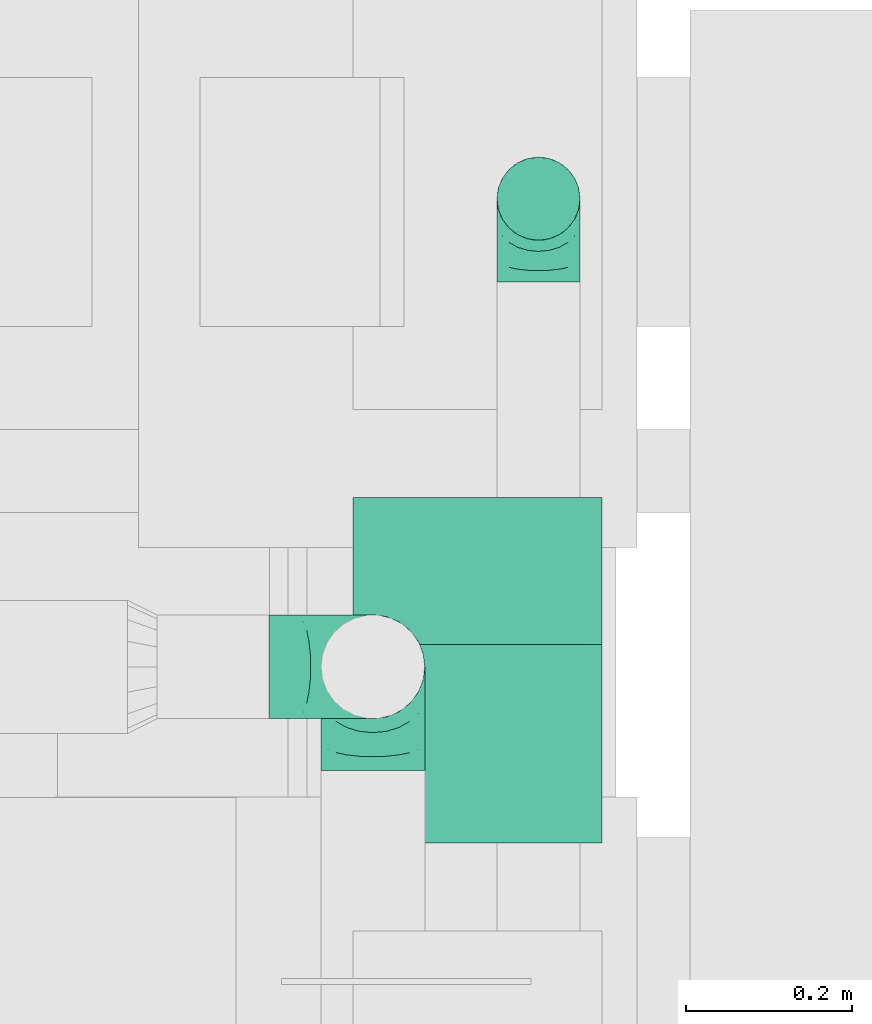
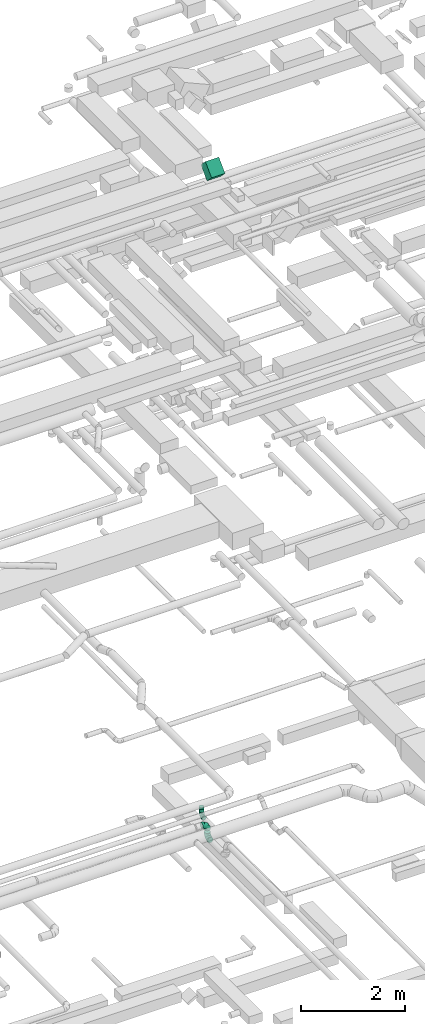
# One storey, part 110 of 337: 4 flow fittings, 2 flow segments.
"""IFC2X3 building model written with IfcOpenShell, lengths in millimetres."""

from ifc_helpers import new_model, entity, si_unit, converted_unit, derived_unit, direction, frame, frame_2d, origin, origin_2d_with_axis, place, context, subcontext, project, spatial, rectangle, circle, extrude, faceted_brep, source, transform, mapped, material, type_object, type_shapes, element, save


model = new_model("IFC2X3")

# Units and contexts
model_context = context("Model", 3, precision=0.01, world=origin(), true_north=direction((6.12303176911189e-17, 1.0)))
body_context = subcontext(model_context, "Body", "Model", "MODEL_VIEW")
ifc_project = project(units=[si_unit("LENGTHUNIT", "METRE", prefix="MILLI"), si_unit("AREAUNIT", "SQUARE_METRE"), si_unit("VOLUMEUNIT", "CUBIC_METRE"), converted_unit("PLANEANGLEUNIT", "DEGREE", entity("IfcRatioMeasure", 0.0174532925199433), si_unit("PLANEANGLEUNIT", "RADIAN"), dimensions=[0, 0, 0, 0, 0, 0, 0]), si_unit("MASSUNIT", "GRAM", prefix="KILO"), derived_unit("MASSDENSITYUNIT", [(si_unit("MASSUNIT", "GRAM", prefix="KILO"), 1), (si_unit("LENGTHUNIT", "METRE"), -3)]), derived_unit("MOMENTOFINERTIAUNIT", [(si_unit("LENGTHUNIT", "METRE"), 4)]), si_unit("TIMEUNIT", "SECOND"), si_unit("FREQUENCYUNIT", "HERTZ"), si_unit("THERMODYNAMICTEMPERATUREUNIT", "DEGREE_CELSIUS"), derived_unit("THERMALTRANSMITTANCEUNIT", [(si_unit("MASSUNIT", "GRAM", prefix="KILO"), 1), (si_unit("THERMODYNAMICTEMPERATUREUNIT", "KELVIN"), -1), (si_unit("TIMEUNIT", "SECOND"), -3)]), derived_unit("VOLUMETRICFLOWRATEUNIT", [(si_unit("LENGTHUNIT", "METRE"), 3), (si_unit("TIMEUNIT", "SECOND"), -1)]), derived_unit("MASSFLOWRATEUNIT", [(si_unit("MASSUNIT", "GRAM", prefix="KILO"), 1), (si_unit("TIMEUNIT", "SECOND"), -1)]), derived_unit("ROTATIONALFREQUENCYUNIT", [(si_unit("TIMEUNIT", "SECOND"), -1)]), si_unit("ELECTRICCURRENTUNIT", "AMPERE"), si_unit("ELECTRICVOLTAGEUNIT", "VOLT"), si_unit("POWERUNIT", "WATT"), si_unit("FORCEUNIT", "NEWTON", prefix="KILO"), si_unit("ILLUMINANCEUNIT", "LUX"), si_unit("LUMINOUSFLUXUNIT", "LUMEN"), si_unit("LUMINOUSINTENSITYUNIT", "CANDELA"), derived_unit("USERDEFINED", [(si_unit("MASSUNIT", "GRAM", prefix="KILO"), -1), (si_unit("LENGTHUNIT", "METRE"), -2), (si_unit("TIMEUNIT", "SECOND"), 3), (si_unit("LUMINOUSFLUXUNIT", "LUMEN"), 1)]), derived_unit("LINEARVELOCITYUNIT", [(si_unit("LENGTHUNIT", "METRE"), 1), (si_unit("TIMEUNIT", "SECOND"), -1)]), si_unit("PRESSUREUNIT", "PASCAL"), derived_unit("USERDEFINED", [(si_unit("LENGTHUNIT", "METRE"), -2), (si_unit("MASSUNIT", "GRAM", prefix="KILO"), 1), (si_unit("TIMEUNIT", "SECOND"), -2)]), derived_unit("LINEARFORCEUNIT", [(si_unit("MASSUNIT", "GRAM", prefix="KILO"), 1), (si_unit("LENGTHUNIT", "METRE"), 1), (si_unit("TIMEUNIT", "SECOND"), -2), (si_unit("LENGTHUNIT", "METRE"), -1)]), derived_unit("PLANARFORCEUNIT", [(si_unit("MASSUNIT", "GRAM", prefix="KILO"), 1), (si_unit("LENGTHUNIT", "METRE"), 1), (si_unit("TIMEUNIT", "SECOND"), -2), (si_unit("LENGTHUNIT", "METRE"), -2)])], contexts=[model_context])

# Site, building, storey
site_placement = place(None, origin())
site = spatial("IfcSite", under=ifc_project, at=site_placement, CompositionType="ELEMENT")
building_placement = place(site_placement, origin())
building = spatial("IfcBuilding", under=site, at=building_placement, CompositionType="ELEMENT")
storey_placement = place(building_placement, origin())
storey = spatial("IfcBuildingStorey", under=building, at=storey_placement, CompositionType="ELEMENT", Elevation=0.0)

# Flow segments
duct_segment_type_1 = type_object("IfcDuctSegmentType", PredefinedType="NOTDEFINED")
flow_segment_1_placement = place(storey_placement, frame((18399.92, 11862.69, 18742.16)))
element("IfcFlowSegment", 1, at=flow_segment_1_placement, inside=storey, type_object=duct_segment_type_1, context=body_context, shape_type="SweptSolid", body=[
    extrude(rectangle(XDim=250.0, YDim=300.000000000001, at=frame_2d((0.0, 0.0), x_axis=(0.0, 1.0))), frame((150.0, 88.39, 88.39), z_axis=(0.0, 0.707106781186504, 0.707106781186591), x_axis=(-1.0, 0.0, 0.0)), (0.0, 0.0, 1.0), 337.867965644152),
])
duct_segment_type_2 = type_object("IfcDuctSegmentType", PredefinedType="NOTDEFINED")
flow_segment_2_placement = place(storey_placement, frame((18571.85, 12586.23, 3480.0)))
element("IfcFlowSegment", 2, at=flow_segment_2_placement, inside=storey, type_object=duct_segment_type_2, context=body_context, shape_type="SweptSolid", body=[
    extrude(circle(Radius=50.0, at=origin_2d_with_axis()), frame((51.6, 51.6, 0.0), z_axis=(0.0, 0.0, 1.0), x_axis=(-1.0, 0.0, 0.0)), (0.0, 0.0, 1.0), 69.9999999999982),
])

# Flow fittings
ifc_material = material()
duct_fitting_type_1 = type_object("IfcDuctFittingType", PredefinedType="NOTDEFINED", material=ifc_material)
shared_shape_1 = source(origin(), body_context, "Body", "Brep", [
    faceted_brep([(-100.0, 0.0, -50.0), (-100.0, -12.94, -48.3), (-100.0, -25.0, -43.3), (-100.0, -35.36, -35.36), (-100.0, -43.3, -25.0), (-100.0, -48.3, -12.94), (-100.0, -50.0, 0.0), (-100.0, -48.3, 12.94), (-100.0, -43.3, 25.0), (-100.0, -35.36, 35.36), (-100.0, -25.0, 43.3), (-100.0, -12.94, 48.3), (-100.0, 0.0, 50.0), (-100.0, 12.94, 48.3), (-100.0, 25.0, 43.3), (-100.0, 35.36, 35.36), (-100.0, 43.3, 25.0), (-100.0, 48.3, 12.94), (-100.0, 50.0, 0.0), (-100.0, 48.3, -12.94), (-100.0, 43.3, -25.0), (-100.0, 35.36, -35.36), (-100.0, 25.0, -43.3), (-100.0, 12.94, -48.3), (-76.67, 12.94, 48.3), (-79.9, 25.0, 43.3), (-73.21, 0.0, 50.0), (-82.68, 35.36, 35.36), (-86.15, 48.3, 12.94), (-86.6, 50.0, 0.0), (-84.81, 43.3, 25.0), (-84.81, 43.3, -25.0), (-82.68, 35.36, -35.36), (-86.15, 48.3, -12.94), (-76.67, 12.94, -48.3), (-73.21, 0.0, -50.0), (-79.9, 25.0, -43.3), (-69.74, -12.94, -48.3), (-66.51, -25.0, -43.3), (-63.73, -35.36, -35.36), (-61.6, -43.3, -25.0), (-60.26, -48.3, -12.94), (-59.81, -50.0, 0.0), (-60.26, -48.3, 12.94), (-61.6, -43.3, 25.0), (-63.73, -35.36, 35.36), (-66.51, -25.0, 43.3), (-69.74, -12.94, 48.3), (-36.27, 36.27, 48.3), (-45.1, 45.1, 43.3), (-26.79, 26.79, 50.0), (-52.68, 52.68, 35.36), (-58.49, 58.49, 25.0), (-62.15, 62.15, 12.94), (-63.4, 63.4, 0.0), (-62.15, 62.15, -12.94), (-58.49, 58.49, -25.0), (-52.68, 52.68, -35.36), (-36.27, 36.27, -48.3), (-26.79, 26.79, -50.0), (-45.1, 45.1, -43.3), (-17.32, 17.32, -48.3), (-8.49, 8.49, -43.3), (-0.91, 0.91, -35.36), (4.9, -4.9, -25.0), (8.56, -8.56, -12.94), (9.81, -9.81, 0.0), (8.56, -8.56, 12.94), (4.9, -4.9, 25.0), (-0.91, 0.91, 35.36), (-8.49, 8.49, 43.3), (-17.32, 17.32, 48.3), (-12.94, 76.67, 48.3), (-25.0, 79.9, 43.3), (0.0, 73.21, 50.0), (-35.36, 82.68, 35.36), (-43.3, 84.81, 25.0), (-48.3, 86.15, 12.94), (-50.0, 86.6, 0.0), (-48.3, 86.15, -12.94), (-43.3, 84.81, -25.0), (-35.36, 82.68, -35.36), (-12.94, 76.67, -48.3), (0.0, 73.21, -50.0), (-25.0, 79.9, -43.3), (12.94, 69.74, -48.3), (25.0, 66.51, -43.3), (35.36, 63.73, -35.36), (43.3, 61.6, -25.0), (48.3, 60.26, -12.94), (50.0, 59.81, 0.0), (48.3, 60.26, 12.94), (43.3, 61.6, 25.0), (35.36, 63.73, 35.36), (25.0, 66.51, 43.3), (12.94, 69.74, 48.3), (-12.94, 100.0, -48.3), (-25.0, 100.0, -43.3), (-35.36, 100.0, -35.36), (-43.3, 100.0, -25.0), (-48.3, 100.0, -12.94), (-50.0, 100.0, 0.0), (-48.3, 100.0, 12.94), (-43.3, 100.0, 25.0), (-35.36, 100.0, 35.36), (-25.0, 100.0, 43.3), (-12.94, 100.0, 48.3), (0.0, 100.0, 50.0), (12.94, 100.0, 48.3), (25.0, 100.0, 43.3), (35.36, 100.0, 35.36), (43.3, 100.0, 25.0), (48.3, 100.0, 12.94), (50.0, 100.0, 0.0), (48.3, 100.0, -12.94), (43.3, 100.0, -25.0), (35.36, 100.0, -35.36), (25.0, 100.0, -43.3), (12.94, 100.0, -48.3), (0.0, 100.0, -50.0)], [[[0, 1, 2, 3, 4, 5, 6, 7, 8, 9, 10, 11, 12, 13, 14, 15, 16, 17, 18, 19, 20, 21, 22, 23]], [[24, 25, 14, 13]], [[26, 24, 13, 12]], [[14, 25, 27, 15]], [[28, 29, 18, 17]], [[30, 28, 17, 16]], [[15, 27, 30, 16]], [[20, 31, 32, 21]], [[33, 31, 20, 19]], [[18, 29, 33, 19]], [[34, 35, 0, 23]], [[36, 34, 23, 22]], [[32, 36, 22, 21]], [[2, 1, 37, 38]], [[3, 2, 38, 39]], [[0, 35, 37, 1]], [[5, 4, 40, 41]], [[6, 5, 41, 42]], [[3, 39, 40, 4]], [[6, 42, 43, 7]], [[7, 43, 44, 8]], [[8, 44, 45, 9]], [[10, 46, 47, 11]], [[11, 47, 26, 12]], [[10, 9, 45, 46]], [[48, 49, 25, 24]], [[50, 48, 24, 26]], [[27, 25, 49, 51]], [[52, 53, 28, 30]], [[51, 52, 30, 27]], [[29, 28, 53, 54]], [[55, 56, 31, 33]], [[54, 55, 33, 29]], [[57, 32, 31, 56]], [[58, 59, 35, 34]], [[60, 58, 34, 36]], [[57, 60, 36, 32]], [[37, 35, 59, 61]], [[38, 37, 61, 62]], [[39, 38, 62, 63]], [[41, 40, 64, 65]], [[42, 41, 65, 66]], [[63, 64, 40, 39]], [[43, 42, 66, 67]], [[44, 43, 67, 68]], [[68, 69, 45, 44]], [[46, 45, 69, 70]], [[47, 46, 70, 71]], [[26, 47, 71, 50]], [[72, 73, 49, 48]], [[74, 72, 48, 50]], [[51, 49, 73, 75]], [[76, 77, 53, 52]], [[75, 76, 52, 51]], [[54, 53, 77, 78]], [[79, 80, 56, 55]], [[78, 79, 55, 54]], [[81, 57, 56, 80]], [[82, 83, 59, 58]], [[84, 82, 58, 60]], [[81, 84, 60, 57]], [[61, 59, 83, 85]], [[62, 61, 85, 86]], [[63, 62, 86, 87]], [[65, 64, 88, 89]], [[66, 65, 89, 90]], [[87, 88, 64, 63]], [[67, 66, 90, 91]], [[68, 67, 91, 92]], [[92, 93, 69, 68]], [[70, 69, 93, 94]], [[71, 70, 94, 95]], [[50, 71, 95, 74]], [[96, 97, 98, 99, 100, 101, 102, 103, 104, 105, 106, 107, 108, 109, 110, 111, 112, 113, 114, 115, 116, 117, 118, 119]], [[72, 74, 107, 106]], [[73, 72, 106, 105]], [[75, 73, 105, 104]], [[77, 76, 103, 102]], [[78, 77, 102, 101]], [[75, 104, 103, 76]], [[78, 101, 100, 79]], [[79, 100, 99, 80]], [[80, 99, 98, 81]], [[96, 119, 83, 82]], [[97, 96, 82, 84]], [[84, 81, 98, 97]], [[83, 119, 118, 85]], [[85, 118, 117, 86]], [[86, 117, 116, 87]], [[88, 115, 114, 89]], [[89, 114, 113, 90]], [[87, 116, 115, 88]], [[91, 90, 113, 112]], [[92, 91, 112, 111]], [[93, 92, 111, 110]], [[95, 94, 109, 108]], [[74, 95, 108, 107]], [[110, 109, 94, 93]]]),
])
type_shapes(duct_fitting_type_1, [shared_shape_1])
flow_fitting_1_placement = place(storey_placement, frame((18623.44, 12637.83, 3380.0), z_axis=(-1.0, 0.0, 0.0), x_axis=(0.0, 0.0, -1.0)))
element("IfcFlowFitting", 3, at=flow_fitting_1_placement, inside=storey, type_object=duct_fitting_type_1, material=ifc_material, context=body_context, shape_type="MappedRepresentation", body=[
    mapped(shared_shape_1, transform((0.0, 0.0, 0.0), scale=1.0)),
])
duct_fitting_type_2 = type_object("IfcDuctFittingType", PredefinedType="NOTDEFINED", material=ifc_material)
shared_shape_2 = source(origin(), body_context, "Body", "Brep", [
    faceted_brep([(-125.0, 0.0, -62.5), (-125.0, -16.18, -60.37), (-125.0, -31.25, -54.13), (-125.0, -44.19, -44.19), (-125.0, -54.13, -31.25), (-125.0, -60.37, -16.18), (-125.0, -62.5, 0.0), (-125.0, -60.37, 16.18), (-125.0, -54.13, 31.25), (-125.0, -44.19, 44.19), (-125.0, -31.25, 54.13), (-125.0, -16.18, 60.37), (-125.0, 0.0, 62.5), (-125.0, 16.18, 60.37), (-125.0, 31.25, 54.13), (-125.0, 44.19, 44.19), (-125.0, 54.13, 31.25), (-125.0, 60.37, 16.18), (-125.0, 62.5, 0.0), (-125.0, 60.37, -16.18), (-125.0, 54.13, -31.25), (-125.0, 44.19, -44.19), (-125.0, 31.25, -54.13), (-125.0, 16.18, -60.37), (-95.84, 16.18, 60.37), (-99.88, 31.25, 54.13), (-91.51, 0.0, 62.5), (-103.35, 44.19, 44.19), (-107.68, 60.37, 16.18), (-108.25, 62.5, 0.0), (-106.01, 54.13, 31.25), (-106.01, 54.13, -31.25), (-103.35, 44.19, -44.19), (-107.68, 60.37, -16.18), (-95.84, 16.18, -60.37), (-91.51, 0.0, -62.5), (-99.88, 31.25, -54.13), (-87.17, -16.18, -60.37), (-83.13, -31.25, -54.13), (-79.66, -44.19, -44.19), (-77.0, -54.13, -31.25), (-75.33, -60.37, -16.18), (-74.76, -62.5, 0.0), (-75.33, -60.37, 16.18), (-77.0, -54.13, 31.25), (-79.66, -44.19, 44.19), (-83.13, -31.25, 54.13), (-87.17, -16.18, 60.37), (-45.34, 45.34, 60.37), (-56.37, 56.37, 54.13), (-33.49, 33.49, 62.5), (-65.85, 65.85, 44.19), (-73.12, 73.12, 31.25), (-77.69, 77.69, 16.18), (-79.25, 79.25, 0.0), (-77.69, 77.69, -16.18), (-73.12, 73.12, -31.25), (-65.85, 65.85, -44.19), (-45.34, 45.34, -60.37), (-33.49, 33.49, -62.5), (-56.37, 56.37, -54.13), (-21.65, 21.65, -60.37), (-10.62, 10.62, -54.13), (-1.14, 1.14, -44.19), (6.13, -6.13, -31.25), (10.7, -10.7, -16.18), (12.26, -12.26, 0.0), (10.7, -10.7, 16.18), (6.13, -6.13, 31.25), (-1.14, 1.14, 44.19), (-10.62, 10.62, 54.13), (-21.65, 21.65, 60.37), (-16.18, 95.84, 60.37), (-31.25, 99.88, 54.13), (0.0, 91.51, 62.5), (-44.19, 103.35, 44.19), (-54.13, 106.01, 31.25), (-60.37, 107.68, 16.18), (-62.5, 108.25, 0.0), (-60.37, 107.68, -16.18), (-54.13, 106.01, -31.25), (-44.19, 103.35, -44.19), (-16.18, 95.84, -60.37), (0.0, 91.51, -62.5), (-31.25, 99.88, -54.13), (16.18, 87.17, -60.37), (31.25, 83.13, -54.13), (44.19, 79.66, -44.19), (54.13, 77.0, -31.25), (60.37, 75.33, -16.18), (62.5, 74.76, 0.0), (60.37, 75.33, 16.18), (54.13, 77.0, 31.25), (44.19, 79.66, 44.19), (31.25, 83.13, 54.13), (16.18, 87.17, 60.37), (-16.18, 125.0, -60.37), (-31.25, 125.0, -54.13), (-44.19, 125.0, -44.19), (-54.13, 125.0, -31.25), (-60.37, 125.0, -16.18), (-62.5, 125.0, 0.0), (-60.37, 125.0, 16.18), (-54.13, 125.0, 31.25), (-44.19, 125.0, 44.19), (-31.25, 125.0, 54.13), (-16.18, 125.0, 60.37), (0.0, 125.0, 62.5), (16.18, 125.0, 60.37), (31.25, 125.0, 54.13), (44.19, 125.0, 44.19), (54.13, 125.0, 31.25), (60.37, 125.0, 16.18), (62.5, 125.0, 0.0), (60.37, 125.0, -16.18), (54.13, 125.0, -31.25), (44.19, 125.0, -44.19), (31.25, 125.0, -54.13), (16.18, 125.0, -60.37), (0.0, 125.0, -62.5)], [[[0, 1, 2, 3, 4, 5, 6, 7, 8, 9, 10, 11, 12, 13, 14, 15, 16, 17, 18, 19, 20, 21, 22, 23]], [[24, 25, 14, 13]], [[26, 24, 13, 12]], [[14, 25, 27, 15]], [[28, 29, 18, 17]], [[30, 28, 17, 16]], [[15, 27, 30, 16]], [[20, 31, 32, 21]], [[33, 31, 20, 19]], [[18, 29, 33, 19]], [[34, 35, 0, 23]], [[36, 34, 23, 22]], [[21, 32, 36, 22]], [[1, 0, 35, 37]], [[2, 1, 37, 38]], [[38, 39, 3, 2]], [[5, 4, 40, 41]], [[6, 5, 41, 42]], [[39, 40, 4, 3]], [[6, 42, 43, 7]], [[7, 43, 44, 8]], [[45, 9, 8, 44]], [[9, 45, 46, 10]], [[10, 46, 47, 11]], [[26, 12, 11, 47]], [[48, 49, 25, 24]], [[50, 48, 24, 26]], [[27, 25, 49, 51]], [[52, 53, 28, 30]], [[51, 52, 30, 27]], [[29, 28, 53, 54]], [[55, 56, 31, 33]], [[54, 55, 33, 29]], [[57, 32, 31, 56]], [[58, 59, 35, 34]], [[60, 58, 34, 36]], [[57, 60, 36, 32]], [[37, 35, 59, 61]], [[38, 37, 61, 62]], [[39, 38, 62, 63]], [[41, 40, 64, 65]], [[42, 41, 65, 66]], [[63, 64, 40, 39]], [[43, 42, 66, 67]], [[44, 43, 67, 68]], [[68, 69, 45, 44]], [[46, 45, 69, 70]], [[47, 46, 70, 71]], [[26, 47, 71, 50]], [[72, 73, 49, 48]], [[74, 72, 48, 50]], [[51, 49, 73, 75]], [[76, 77, 53, 52]], [[75, 76, 52, 51]], [[54, 53, 77, 78]], [[79, 80, 56, 55]], [[78, 79, 55, 54]], [[81, 57, 56, 80]], [[82, 83, 59, 58]], [[84, 82, 58, 60]], [[81, 84, 60, 57]], [[61, 59, 83, 85]], [[62, 61, 85, 86]], [[63, 62, 86, 87]], [[65, 64, 88, 89]], [[66, 65, 89, 90]], [[87, 88, 64, 63]], [[67, 66, 90, 91]], [[68, 67, 91, 92]], [[92, 93, 69, 68]], [[70, 69, 93, 94]], [[71, 70, 94, 95]], [[50, 71, 95, 74]], [[96, 97, 98, 99, 100, 101, 102, 103, 104, 105, 106, 107, 108, 109, 110, 111, 112, 113, 114, 115, 116, 117, 118, 119]], [[72, 74, 107, 106]], [[73, 72, 106, 105]], [[75, 73, 105, 104]], [[77, 76, 103, 102]], [[78, 77, 102, 101]], [[75, 104, 103, 76]], [[78, 101, 100, 79]], [[79, 100, 99, 80]], [[80, 99, 98, 81]], [[96, 119, 83, 82]], [[97, 96, 82, 84]], [[84, 81, 98, 97]], [[83, 119, 118, 85]], [[85, 118, 117, 86]], [[116, 87, 86, 117]], [[88, 115, 114, 89]], [[89, 114, 113, 90]], [[115, 88, 87, 116]], [[91, 90, 113, 112]], [[92, 91, 112, 111]], [[111, 110, 93, 92]], [[95, 94, 109, 108]], [[74, 95, 108, 107]], [[110, 109, 94, 93]]]),
])
type_shapes(duct_fitting_type_2, [shared_shape_2])
for number, where, z_axis, x_axis in (
    (4, (18424.1, 12074.54, 3600.0), (0.0, 1.0, 0.0), (1.0, 0.0, 0.0)),
    (5, (18424.1, 12074.54, 3290.0), (-1.0, 0.0, 0.0), (0.0, 0.0, -1.0)),
):
    element("IfcFlowFitting", number, at=place(storey_placement, frame(where, z_axis=z_axis, x_axis=x_axis)), inside=storey, type_object=duct_fitting_type_2, material=ifc_material, context=body_context, shape_type="MappedRepresentation", body=[
        mapped(shared_shape_2, transform((0.0, 0.0, 0.0), scale=1.0)),
    ])
duct_fitting_type_3 = type_object("IfcDuctFittingType", PredefinedType="NOTDEFINED", material=ifc_material)
shared_shape_3 = source(origin(), body_context, "Body", "Brep", [
    faceted_brep([(20.0, 0.0, -50.0), (20.0, 12.94, -48.3), (20.0, 25.0, -43.3), (20.0, 35.36, -35.36), (20.0, 43.3, -25.0), (20.0, 48.3, -12.94), (20.0, 50.0, 0.0), (20.0, 48.3, 12.94), (20.0, 43.3, 25.0), (20.0, 35.36, 35.36), (20.0, 25.0, 43.3), (20.0, 12.94, 48.3), (20.0, 0.0, 50.0), (20.0, -12.94, 48.3), (20.0, -25.0, 43.3), (20.0, -35.36, 35.36), (20.0, -43.3, 25.0), (20.0, -48.3, 12.94), (20.0, -50.0, 0.0), (20.0, -48.3, -12.94), (20.0, -43.3, -25.0), (20.0, -35.36, -35.36), (20.0, -25.0, -43.3), (20.0, -12.94, -48.3), (0.0, 0.0, 50.0), (-23.65, 0.0, 50.0), (-23.65, -12.94, 48.3), (0.0, -12.94, 48.3), (-23.65, -25.0, 43.3), (0.0, -25.0, 43.3), (0.0, -35.36, 35.36), (-23.65, -35.36, 35.36), (0.0, -43.3, 25.0), (-23.65, -43.3, 25.0), (-23.65, -48.3, 12.94), (0.0, -48.3, 12.94), (-23.65, -50.0, 0.0), (0.0, -50.0, 0.0), (-23.65, -48.3, -12.94), (0.0, -48.3, -12.94), (-23.65, -43.3, -25.0), (0.0, -43.3, -25.0), (0.0, -35.36, -35.36), (-23.65, -35.36, -35.36), (0.0, -25.0, -43.3), (-23.65, -25.0, -43.3), (-23.65, -12.94, -48.3), (0.0, -12.94, -48.3), (-23.65, 0.0, -50.0), (0.0, 0.0, -50.0), (-23.65, 12.94, -48.3), (0.0, 12.94, -48.3), (-23.65, 25.0, -43.3), (0.0, 25.0, -43.3), (0.0, 35.36, -35.36), (-23.65, 35.36, -35.36), (0.0, 43.3, -25.0), (-23.65, 43.3, -25.0), (-23.65, 48.3, -12.94), (0.0, 48.3, -12.94), (-23.65, 50.0, 0.0), (0.0, 50.0, 0.0), (-23.65, 48.3, 12.94), (0.0, 48.3, 12.94), (-23.65, 43.3, 25.0), (0.0, 43.3, 25.0), (0.0, 35.36, 35.36), (-23.65, 35.36, 35.36), (0.0, 25.0, 43.3), (-23.65, 25.0, 43.3), (-23.65, 12.94, 48.3), (0.0, 12.94, 48.3)], [[[0, 1, 2, 3, 4, 5, 6, 7, 8, 9, 10, 11, 12, 13, 14, 15, 16, 17, 18, 19, 20, 21, 22, 23]], [[13, 12, 24, 25, 26, 27]], [[14, 13, 27, 26, 28, 29]], [[30, 15, 14, 29, 28, 31]], [[17, 16, 32, 33, 34, 35]], [[18, 17, 35, 34, 36, 37]], [[32, 16, 15, 30, 31, 33]], [[19, 18, 37, 36, 38, 39]], [[20, 19, 39, 38, 40, 41]], [[42, 21, 20, 41, 40, 43]], [[23, 22, 44, 45, 46, 47]], [[0, 23, 47, 46, 48, 49]], [[44, 22, 21, 42, 43, 45]], [[1, 0, 49, 48, 50, 51]], [[2, 1, 51, 50, 52, 53]], [[54, 3, 2, 53, 52, 55]], [[5, 4, 56, 57, 58, 59]], [[6, 5, 59, 58, 60, 61]], [[56, 4, 3, 54, 55, 57]], [[7, 6, 61, 60, 62, 63]], [[8, 7, 63, 62, 64, 65]], [[66, 9, 8, 65, 64, 67]], [[11, 10, 68, 69, 70, 71]], [[12, 11, 71, 70, 25, 24]], [[68, 10, 9, 66, 67, 69]], [[46, 45, 43, 40, 38, 36, 34, 33, 31, 28, 26, 25, 70, 69, 67, 64, 62, 60, 58, 57, 55, 52, 50, 48]]]),
])
type_shapes(duct_fitting_type_3, [shared_shape_3])
flow_fitting_2_placement = place(storey_placement, frame((18623.44, 12637.83, 3570.0), z_axis=(0.0, -1.0, 0.0), x_axis=(0.0, 0.0, -1.0)))
element("IfcFlowFitting", 6, at=flow_fitting_2_placement, inside=storey, type_object=duct_fitting_type_3, material=ifc_material, context=body_context, shape_type="MappedRepresentation", body=[
    mapped(shared_shape_3, transform((0.0, 0.0, 0.0), scale=1.0)),
])

save(model, "model.ifc")
